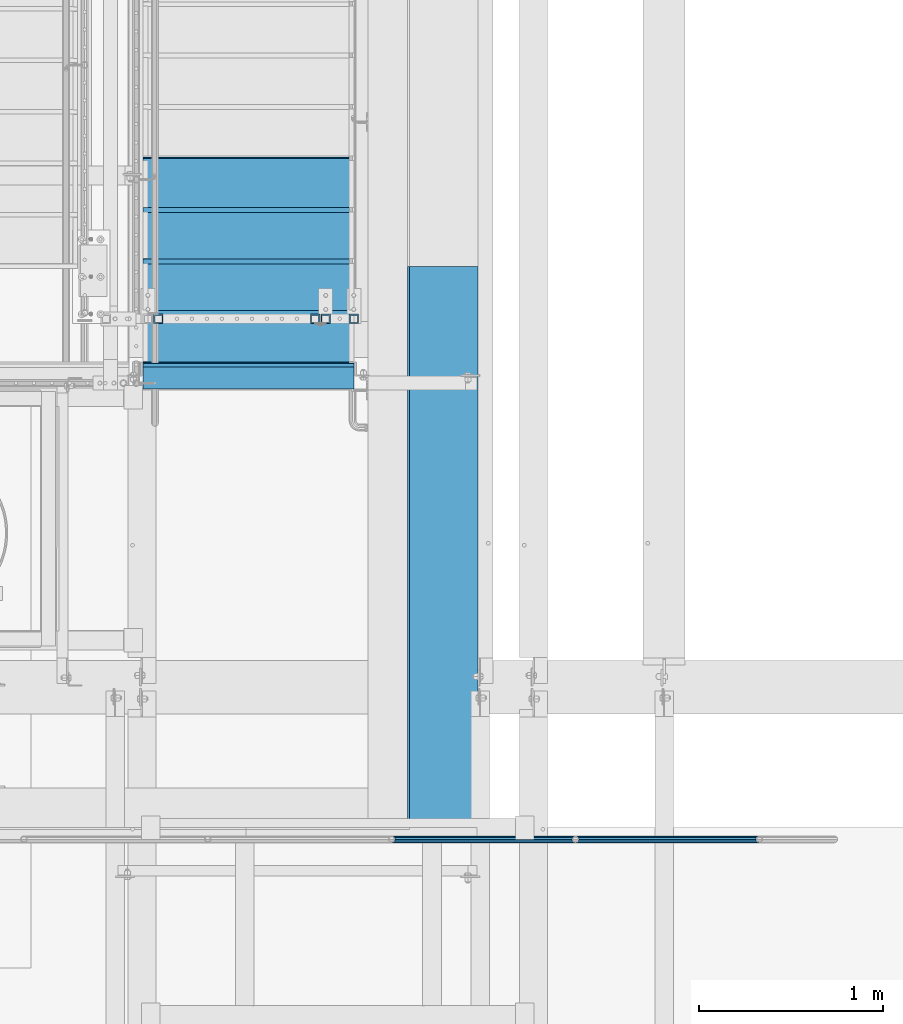
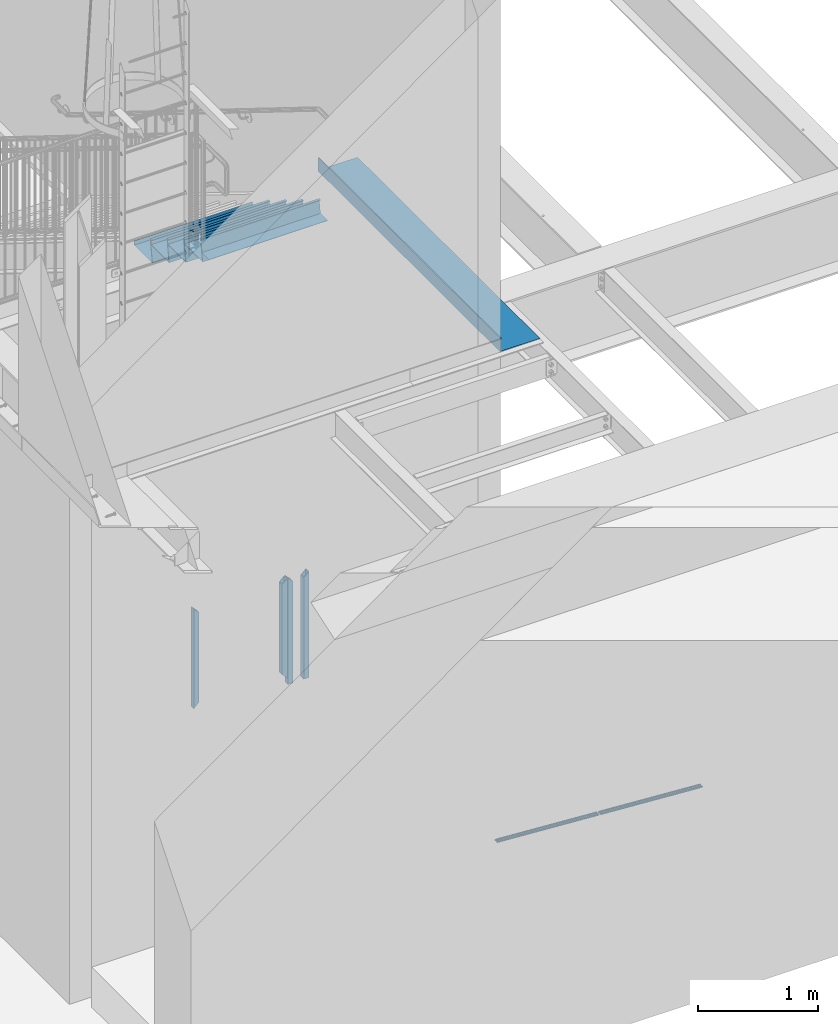
# One storey, part 1088 of 1763: 12 beams, 4 elements without a shape of their own.
"""IFC2X3 building model written with IfcOpenShell, lengths in millimetres."""

from ifc_helpers import new_model, si_unit, frame, origin_with_axes, place, context, subcontext, project, spatial, faceted_brep, material, type_object, element, aggregate, save


model = new_model("IFC2X3")

# Units and contexts
model_context = context("Model", 3, precision=1e-05, world=origin_with_axes())
body_context = subcontext(model_context, "Body", "Model", "MODEL_VIEW")
ifc_project = project(units=[si_unit("LENGTHUNIT", "METRE", prefix="MILLI"), si_unit("AREAUNIT", "SQUARE_METRE"), si_unit("VOLUMEUNIT", "CUBIC_METRE"), si_unit("MASSUNIT", "GRAM", prefix="KILO"), si_unit("TIMEUNIT", "SECOND"), si_unit("PLANEANGLEUNIT", "RADIAN"), si_unit("SOLIDANGLEUNIT", "STERADIAN"), si_unit("THERMODYNAMICTEMPERATUREUNIT", "DEGREE_CELSIUS"), si_unit("LUMINOUSINTENSITYUNIT", "LUMEN")], contexts=[model_context])

# Site, building, storey
site_placement = place(None, origin_with_axes())
site = spatial("IfcSite", under=ifc_project, at=site_placement, CompositionType="ELEMENT")
building_placement = place(site_placement, origin_with_axes())
building = spatial("IfcBuilding", under=site, at=building_placement, Name="Undefined", CompositionType="ELEMENT")
storey_placement = place(building_placement, origin_with_axes())
storey = spatial("IfcBuildingStorey", under=building, at=storey_placement, Name="Undefined", CompositionType="ELEMENT", Elevation=0.0)

# Assembly, beams
assembly_1_placement = place(storey_placement, origin_with_axes())
assembly_1 = element("IfcElementAssembly", 1, at=assembly_1_placement, inside=storey, Name="GUARDRAIL", AssemblyPlace="NOTDEFINED", PredefinedType="RIGID_FRAME")
ifc_material_1 = material()
beam_type_1 = type_object("IfcBeamType", PredefinedType="NOTDEFINED")
beam_1_placement = place(assembly_1_placement, frame((-81897.3716560389, 29197.2999999971, 147.984652267512), z_axis=(0.0, -1.0, 0.0), x_axis=(-0.997891522550524, 0.0, 0.0649038459707657)))
beam_1 = element("IfcBeam", 2, at=beam_1_placement, type_object=beam_type_1, material=ifc_material_1, Name="GUARDRAIL", context=body_context, shape_type="Brep", body=[
    faceted_brep([(1.45519152283669e-11, 1.81898940354586e-12, 19.0499999999993), (8.92561031517107, 9.52499999999873, 16.4977839420935), (10.1646410493704, -9.524999999996, 16.4977839420935), (10.1646410493704, -9.52499999999509, -16.4977839420935), (8.92561031517107, 9.52499999999873, -16.4977839420935), (1.45519152283669e-11, 1.81898940354586e-12, -19.0499999999993), (17.6056747381954, -16.4977839420881, -9.52500000000146), (17.2784488961188, -11.4667123799518, -9.52500000000146), (13.2411789904436, -7.68349999999555, -13.3082123799541), (10.6782988949999, 1.81898940354586e-12, -15.3669999999984), (12.2416941982665, 7.68350000000009, -13.3082123799541), (15.7868363965099, 11.4667123799545, -9.52500000000146), (15.4596105544624, 16.4977839420917, -9.52500000000146), (18.0907665723062, 15.3669999999984, 0.0), (17.8512206303712, 19.0499999999975, 0.0), (16.1615344449092, 13.3082123799541, -7.68349999999919), (16.1615344449092, 13.3082123799541, 7.68349999999919), (15.7868363965099, 11.4667123799545, 9.52500000000146), (15.4596105544624, 16.4977839420917, 9.52500000000146), (12.2416941982665, 7.68350000000009, 13.3082123799541), (10.6782988949999, 1.81898940354586e-12, 15.3669999999984), (13.2411789904436, -7.68349999999646, 13.3082123799541), (17.2784488961188, -11.4667123799518, 9.52500000000146), (17.6056747381954, -16.4977839420881, 9.52500000000146), (17.8926928863511, -13.3082123799504, 7.68349999999919), (20.0897361567768, -15.3669999999947, 0.0), (20.3292820987263, -19.0499999999938, 0.0), (17.8926928863511, -13.3082123799504, -7.68349999999919), (1000.15019855546, 2.72848410531878e-11, 19.0499999999993), (989.985557506108, 9.5250000000251, 16.4977839420935), (982.544523817283, 16.4977839421163, 9.52500000000146), (1000.15019855548, 2.81943357549608e-11, -19.0499999999993), (989.985557506108, 9.5250000000251, -16.4977839420935), (991.224588240293, -9.52499999997053, -16.4977839420935), (984.690588001031, -16.4977839420635, -9.52500000000146), (982.544523817283, 16.4977839421163, -9.52500000000146), (979.820916456767, 19.050000000022, 0.0), (982.257505670044, 13.3082123799786, 7.68349999999919), (980.060462398702, 15.3670000000229, 0.0), (982.87174965936, 11.46671237998, 9.52500000000146), (982.87174965936, 11.46671237998, -9.52500000000146), (982.257505670044, 13.3082123799786, -7.68349999999919), (986.909019565966, 7.68350000002556, -13.3082123799541), (989.47189966141, 2.81943357549608e-11, -15.3669999999984), (987.908504358144, -7.68349999997099, -13.3082123799541), (984.363362158969, -11.4667123799254, -9.52500000000146), (983.988664111486, -13.3082123799259, -7.68349999999919), (982.059431983173, -15.3669999999702, 0.0), (982.298977925122, -19.0499999999693, 0.0), (984.690588001031, -16.4977839420635, 9.52500000000146), (991.224588240293, -9.52499999997053, 16.4977839420935), (984.363362158969, -11.4667123799254, 9.52500000000146), (987.908504358144, -7.68349999997099, 13.3082123799541), (989.47189966141, 2.72848410531878e-11, 15.3669999999984), (986.909019565966, 7.68350000002465, 13.3082123799541), (983.988664111486, -13.3082123799259, 7.68349999999919)], [[[0, 1, 2]], [[3, 4, 5]], [[6, 7, 8, 9, 10, 11, 12, 4, 3]], [[13, 14, 12, 11, 15]], [[16, 17, 18, 14, 13]], [[2, 1, 18, 17, 19, 20, 21, 22, 23]], [[23, 22, 24, 25, 26]], [[26, 25, 27, 7, 6]], [[28, 29, 1, 0]], [[29, 30, 18, 1]], [[31, 32, 33]], [[33, 34, 6, 3]], [[31, 33, 3, 5]], [[32, 31, 5, 4]], [[35, 32, 4, 12]], [[36, 35, 12, 14]], [[30, 36, 14, 18]], [[37, 38, 36, 30, 39]], [[40, 35, 36, 38, 41]], [[33, 32, 35, 40, 42, 43, 44, 45, 34]], [[34, 45, 46, 47, 48]], [[34, 48, 26, 6]], [[49, 50, 2, 23]], [[48, 49, 23, 26]], [[50, 28, 0, 2]], [[28, 50, 29]], [[49, 51, 52, 53, 54, 39, 30, 29, 50]], [[48, 47, 55, 51, 49]], [[55, 47, 25, 24]], [[21, 52, 51, 55, 24, 22]], [[53, 52, 21, 20]], [[54, 53, 20, 19]], [[37, 39, 54, 19, 17, 16]], [[38, 37, 16, 13]], [[41, 38, 13, 15]], [[10, 42, 40, 41, 15, 11]], [[43, 42, 10, 9]], [[44, 43, 9, 8]], [[46, 45, 44, 8, 7, 27]], [[47, 46, 27, 25]]]),
])
beam_2_placement = place(assembly_1_placement, frame((-82895.4130604548, 29197.2999999971, 212.898246706029), z_axis=(0.0, -1.0, 0.0), x_axis=(-0.997891522550524, 0.0, 0.0649038459707657)))
beam_2 = element("IfcBeam", 3, at=beam_2_placement, type_object=beam_type_1, material=ifc_material_1, Name="GUARDRAIL", context=body_context, shape_type="Brep", body=[
    faceted_brep([(1.45519152283669e-11, 1.81898940354586e-12, 19.0499999999993), (8.92561031517107, 9.52499999999873, 16.4977839420935), (10.1646410493704, -9.524999999996, 16.4977839420935), (10.1646410493704, -9.52499999999509, -16.4977839420935), (8.92561031517107, 9.52499999999873, -16.4977839420935), (1.45519152283669e-11, 1.81898940354586e-12, -19.0499999999993), (17.6056747381954, -16.4977839420881, -9.52500000000146), (17.2784488961188, -11.4667123799518, -9.52500000000146), (13.2411789904436, -7.68349999999555, -13.3082123799541), (10.6782988949999, 1.81898940354586e-12, -15.3669999999984), (12.2416941982665, 7.68350000000009, -13.3082123799541), (15.7868363965099, 11.4667123799545, -9.52500000000146), (15.4596105544624, 16.4977839420917, -9.52500000000146), (18.0907665723062, 15.3669999999984, 0.0), (17.8512206303712, 19.0499999999975, 0.0), (16.1615344449092, 13.3082123799541, -7.68349999999919), (16.1615344449092, 13.3082123799541, 7.68349999999919), (15.7868363965099, 11.4667123799545, 9.52500000000146), (15.4596105544624, 16.4977839420917, 9.52500000000146), (12.2416941982665, 7.68350000000009, 13.3082123799541), (10.6782988949999, 1.81898940354586e-12, 15.3669999999984), (13.2411789904436, -7.68349999999646, 13.3082123799541), (17.2784488961188, -11.4667123799518, 9.52500000000146), (17.6056747381954, -16.4977839420881, 9.52500000000146), (17.8926928863511, -13.3082123799504, 7.68349999999919), (20.0897361567768, -15.3669999999947, 0.0), (20.3292820987263, -19.0499999999938, 0.0), (17.8926928863511, -13.3082123799504, -7.68349999999919), (1000.15019855546, 2.72848410531878e-11, 19.0499999999993), (989.985557506108, 9.5250000000251, 16.4977839420935), (982.544523817283, 16.4977839421163, 9.52500000000146), (1000.15019855548, 2.81943357549608e-11, -19.0499999999993), (989.985557506108, 9.5250000000251, -16.4977839420935), (991.224588240293, -9.52499999997053, -16.4977839420935), (984.690588001031, -16.4977839420635, -9.52500000000146), (982.544523817283, 16.4977839421163, -9.52500000000146), (979.820916456767, 19.050000000022, 0.0), (982.257505670044, 13.3082123799786, 7.68349999999919), (980.060462398702, 15.3670000000229, 0.0), (982.87174965936, 11.46671237998, 9.52500000000146), (982.87174965936, 11.46671237998, -9.52500000000146), (982.257505670044, 13.3082123799786, -7.68349999999919), (986.909019565966, 7.68350000002556, -13.3082123799541), (989.47189966141, 2.81943357549608e-11, -15.3669999999984), (987.908504358144, -7.68349999997099, -13.3082123799541), (984.363362158969, -11.4667123799254, -9.52500000000146), (983.988664111486, -13.3082123799259, -7.68349999999919), (982.059431983173, -15.3669999999702, 0.0), (982.298977925122, -19.0499999999693, 0.0), (984.690588001031, -16.4977839420635, 9.52500000000146), (991.224588240293, -9.52499999997053, 16.4977839420935), (984.363362158969, -11.4667123799254, 9.52500000000146), (987.908504358144, -7.68349999997099, 13.3082123799541), (989.47189966141, 2.72848410531878e-11, 15.3669999999984), (986.909019565966, 7.68350000002465, 13.3082123799541), (983.988664111486, -13.3082123799259, 7.68349999999919)], [[[0, 1, 2]], [[3, 4, 5]], [[6, 7, 8, 9, 10, 11, 12, 4, 3]], [[13, 14, 12, 11, 15]], [[16, 17, 18, 14, 13]], [[2, 1, 18, 17, 19, 20, 21, 22, 23]], [[23, 22, 24, 25, 26]], [[26, 25, 27, 7, 6]], [[28, 29, 1, 0]], [[29, 30, 18, 1]], [[31, 32, 33]], [[33, 34, 6, 3]], [[31, 33, 3, 5]], [[32, 31, 5, 4]], [[35, 32, 4, 12]], [[36, 35, 12, 14]], [[30, 36, 14, 18]], [[37, 38, 36, 30, 39]], [[40, 35, 36, 38, 41]], [[33, 32, 35, 40, 42, 43, 44, 45, 34]], [[34, 45, 46, 47, 48]], [[34, 48, 26, 6]], [[49, 50, 2, 23]], [[48, 49, 23, 26]], [[50, 28, 0, 2]], [[28, 50, 29]], [[49, 51, 52, 53, 54, 39, 30, 29, 50]], [[48, 47, 55, 51, 49]], [[55, 47, 25, 24]], [[21, 52, 51, 55, 24, 22]], [[53, 52, 21, 20]], [[54, 53, 20, 19]], [[37, 39, 54, 19, 17, 16]], [[38, 37, 16, 13]], [[41, 38, 13, 15]], [[10, 42, 40, 41, 15, 11]], [[43, 42, 10, 9]], [[44, 43, 9, 8]], [[46, 45, 44, 8, 7, 27]], [[47, 46, 27, 25]]]),
])
aggregate(assembly_1, [beam_1, beam_2])

assembly_2_placement = place(storey_placement, origin_with_axes())
assembly_2 = element("IfcElementAssembly", 4, at=assembly_2_placement, inside=storey, Name="GATE", AssemblyPlace="NOTDEFINED", PredefinedType="RIGID_FRAME")
beam_type_2 = type_object("IfcBeamType", Name="HSS2X2X1/4", PredefinedType="NOTDEFINED")
beam_3_placement = place(assembly_2_placement, frame((-85159.2872737343, 32023.0500064728, 1346.20003013257), z_axis=(1.0, 0.0, 0.0), x_axis=(0.0, 0.0, -1.0)))
beam_3 = element("IfcBeam", 5, at=beam_3_placement, type_object=beam_type_2, material=ifc_material_1, Name="GUARDRAIL", ObjectType="HSS2X2X1/4", context=body_context, shape_type="Brep", body=[
    faceted_brep([(-44.4500000000053, 19.0499999999993, -19.0500000000029), (-44.4500000000053, -19.0499999999993, -19.0500000000029), (958.851840643746, -19.0499999999993, -19.0500000000029), (958.851840643746, 19.0499999999993, -19.0500000000029), (-6.35000000000082, -19.0499999999993, 19.0500000000029), (920.751840643741, -19.0499999999993, 19.0500000000029), (-6.35000000000082, 19.0499999999993, 19.0500000000029), (920.751840643741, 19.0499999999993, 19.0500000000029), (-50.8000000000061, 25.4000000000015, -25.3999999999942), (1.45519152283669e-11, 25.4000000000015, 25.3999999999796), (914.401840643741, 25.4000000000015, 25.3999999999942), (965.201840643746, 25.4000000000015, -25.3999999999942), (0.0, -25.4000000000015, 25.3999999999942), (914.401840643741, -25.4000000000015, 25.3999999999942), (-50.8000000000061, -25.4000000000015, -25.3999999999942), (965.201840643746, -25.4000000000015, -25.3999999999942)], [[[0, 1, 2, 3]], [[1, 4, 5, 2]], [[4, 6, 7, 5]], [[6, 0, 3, 7]], [[8, 9, 10, 11]], [[9, 12, 13, 10]], [[12, 14, 15, 13]], [[14, 8, 11, 15]], [[13, 15, 11, 10], [5, 7, 3, 2]], [[14, 12, 9, 8], [6, 4, 1, 0]]]),
])
beam_4_placement = place(assembly_2_placement, frame((-84308.3872737343, 32023.0500064728, 1346.20003013257), z_axis=(1.0, 0.0, 0.0), x_axis=(0.0, 0.0, -1.0)))
beam_4 = element("IfcBeam", 6, at=beam_4_placement, type_object=beam_type_2, material=ifc_material_1, Name="GUARDRAIL", ObjectType="HSS2X2X1/4", context=body_context, shape_type="Brep", body=[
    faceted_brep([(-6.34999999999491, 19.0499999999993, -19.0500000000029), (-6.34999999999491, -19.0499999999993, -19.0500000000029), (920.751840643747, -19.0499999999993, -19.0500000000029), (920.751840643747, 19.0499999999993, -19.0500000000029), (-44.4499999999994, -19.0499999999993, 19.0500000000029), (958.851840643751, -19.0499999999993, 19.0500000000029), (-44.4499999999994, 19.0499999999993, 19.0500000000029), (958.851840643751, 19.0499999999993, 19.0500000000029), (-1.45519152283669e-11, 25.4000000000015, -25.3999999999869), (-50.8000000000002, 25.4000000000015, 25.3999999999942), (965.201840643752, 25.4000000000015, 25.3999999999942), (914.401840643746, 25.4000000000015, -25.3999999999942), (-50.8000000000002, -25.4000000000015, 25.3999999999942), (965.201840643752, -25.4000000000015, 25.3999999999942), (-1.45519152283669e-11, -25.4000000000015, -25.3999999999869), (914.401840643746, -25.4000000000015, -25.3999999999942)], [[[0, 1, 2, 3]], [[1, 4, 5, 2]], [[4, 6, 7, 5]], [[6, 0, 3, 7]], [[8, 9, 10, 11]], [[9, 12, 13, 10]], [[12, 14, 15, 13]], [[14, 8, 11, 15]], [[13, 15, 11, 10], [5, 7, 3, 2]], [[14, 12, 9, 8], [6, 4, 1, 0]]]),
])
beam_5_placement = place(assembly_2_placement, frame((-84098.8372737343, 32023.0500064728, 1397.00003013257), z_axis=(1.0, 0.0, 0.0), x_axis=(0.0, 0.0, -1.0)))
beam_5 = element("IfcBeam", 7, at=beam_5_placement, type_object=beam_type_2, material=ifc_material_1, Name="GUARDRAIL", ObjectType="HSS2X2X1/4", context=body_context, shape_type="Brep", body=[
    faceted_brep([(44.4500000000053, 19.0499999999993, -19.0500000000029), (44.4500000000053, -19.0499999999993, -19.0500000000029), (1085.85, -19.0499999999993, -19.0500000000029), (1085.85, 19.0499999999993, -19.0500000000029), (6.35000000000082, -19.0499999999993, 19.0500000000029), (1085.85, -19.0499999999993, 19.0500000000029), (6.35000000000082, 19.0499999999993, 19.0500000000029), (1085.85, 19.0499999999993, 19.0500000000029), (50.7999999999884, 25.3999999999996, -25.3999999999996), (1.45519152283669e-11, 25.4000000000015, 25.3999999999796), (1085.85, 25.4000000000015, 25.3999999999942), (1085.85, 25.4000000000015, -25.3999999999942), (0.0, -25.4000000000015, 25.3999999999942), (1085.85, -25.4000000000015, 25.3999999999942), (50.7999999999884, -25.3999999999996, -25.3999999999996), (1085.85, -25.4000000000015, -25.3999999999942)], [[[0, 1, 2, 3]], [[1, 4, 5, 2]], [[4, 6, 7, 5]], [[6, 0, 3, 7]], [[8, 9, 10, 11]], [[9, 12, 13, 10]], [[12, 14, 15, 13]], [[14, 8, 11, 15]], [[13, 15, 11, 10], [5, 7, 3, 2]], [[14, 12, 9, 8], [6, 4, 1, 0]]]),
])
beam_6_placement = place(assembly_2_placement, frame((-84251.2372737343, 32023.0500064728, 1371.60003013257), z_axis=(1.0, 0.0, 0.0), x_axis=(0.0, 0.0, -1.0)))
beam_6 = element("IfcBeam", 8, at=beam_6_placement, type_object=beam_type_2, material=ifc_material_1, Name="GUARDRAIL", ObjectType="HSS2X2X1/4", context=body_context, shape_type="Brep", body=[
    faceted_brep([(-19.0500000000052, 19.0499999999993, -19.0500000000029), (-19.0500000000052, -19.0499999999993, -19.0500000000029), (1060.45, -19.0499999999993, -19.0500000000029), (1060.45, 19.0499999999993, -19.0500000000029), (19.0499999999993, -19.0499999999993, 19.0500000000029), (1060.45, -19.0499999999993, 19.0500000000029), (19.0499999999993, 19.0499999999993, 19.0500000000029), (1060.45, 19.0499999999993, 19.0500000000029), (-25.400000000006, 25.4000000000015, -25.3999999999942), (25.4000000000001, 25.4000000000015, 25.3999999999942), (1060.45, 25.4000000000015, 25.3999999999942), (1060.45, 25.4000000000015, -25.3999999999942), (25.4000000000001, -25.4000000000015, 25.3999999999942), (1060.45, -25.4000000000015, 25.3999999999942), (-25.400000000006, -25.4000000000015, -25.3999999999942), (1060.45, -25.4000000000015, -25.3999999999942)], [[[0, 1, 2, 3]], [[1, 4, 5, 2]], [[4, 6, 7, 5]], [[6, 0, 3, 7]], [[8, 9, 10, 11]], [[9, 12, 13, 10]], [[12, 14, 15, 13]], [[14, 8, 11, 15]], [[13, 15, 11, 10], [5, 7, 3, 2]], [[14, 12, 9, 8], [6, 4, 1, 0]]]),
])
aggregate(assembly_2, [beam_3, beam_4, beam_5, beam_6])

# Assembly, beam
assembly_3_placement = place(storey_placement, origin_with_axes())
assembly_3 = element("IfcElementAssembly", 9, at=assembly_3_placement, inside=storey, Name="BEAM", AssemblyPlace="NOTDEFINED", PredefinedType="RIGID_FRAME")
ifc_material_2 = material(Name="STEEL/A36")
beam_type_3 = type_object("IfcBeamType", PredefinedType="NOTDEFINED")
beam_7_placement = place(assembly_3_placement, frame((-83425.7372736983, 30784.00575, 5199.0625), z_axis=(0.0, -1.0, 0.0), x_axis=(-1.0, 0.0, 0.0)))
beam_7 = element("IfcBeam", 10, at=beam_7_placement, type_object=beam_type_3, material=ifc_material_2, Name="BENT_PLATE", context=body_context, shape_type="Brep", body=[
    faceted_brep([(0.0, -4.76249999999982, -1524.0), (0.0, -4.76249999999982, 1524.0), (0.0, 4.76249999999982, 1524.0), (0.0, 4.76249999999982, -1524.0), (381.0, 4.76249999999982, 1524.0), (381.0, 4.76249999999982, -1524.0), (371.475000000006, -4.76249999999982, -1524.0), (371.475000000006, -4.76249999999982, 1524.0), (381.0, -134.937496948242, 1524.0), (381.0, -134.937496948242, -1524.0), (371.475000000006, -134.937496948242, 1524.0), (371.475000000006, -134.937496948242, -1524.0)], [[[0, 1, 2, 3]], [[3, 2, 4, 5]], [[1, 0, 6, 7]], [[5, 4, 8, 9]], [[4, 2, 1, 7, 10, 8]], [[7, 6, 11, 10]], [[6, 0, 3, 5, 9, 11]], [[10, 11, 9, 8]]]),
])
aggregate(assembly_3, [beam_7])

# Assembly, beams
assembly_4_placement = place(storey_placement, origin_with_axes())
assembly_4 = element("IfcElementAssembly", 11, at=assembly_4_placement, inside=storey, Name="STRINGER", AssemblyPlace="NOTDEFINED", PredefinedType="RIGID_FRAME")
beam_type_4 = type_object("IfcBeamType", PredefinedType="NOTDEFINED")
beam_8_placement = place(assembly_4_placement, frame((-84670.272101246, 31642.0500001343, 5195.88750001325), z_axis=(-1.0, 0.0, 0.0), x_axis=(0.0, 1.0, 0.0)))
beam_8 = element("IfcBeam", 12, at=beam_8_placement, type_object=beam_type_4, material=ifc_material_2, Name="TREAD", context=body_context, shape_type="Brep", body=[
    faceted_brep([(0.0, -1.58749999999964, -571.5), (0.0, -1.58749999999964, 571.5), (0.0, 1.58749999999964, 571.5), (0.0, 1.58749999999964, -571.5), (122.384764270853, 1.58750000012969, 571.5), (122.384764270853, 1.58750000012969, -571.5), (119.640823364254, -1.58749999987322, -571.5), (119.640823364254, -1.58749999987322, 571.5), (140.855243789152, -124.550469203636, 571.5), (140.855243789152, -124.550469203636, -571.5), (137.713745117184, -125.010481262207, 571.5), (137.713745117184, -125.010481262207, -571.5)], [[[0, 1, 2, 3]], [[3, 2, 4, 5]], [[1, 0, 6, 7]], [[5, 4, 8, 9]], [[4, 2, 1, 7, 10, 8]], [[7, 6, 11, 10]], [[6, 0, 3, 5, 9, 11]], [[10, 11, 9, 8]]]),
])
beam_type_5 = type_object("IfcBeamType", PredefinedType="NOTDEFINED")
beam_9_placement = place(assembly_4_placement, frame((-84670.272101313, 31762.6999999968, 5332.41250001325), z_axis=(-1.0, 0.0, 0.0), x_axis=(0.0, 1.0, 0.0)))
beam_9 = element("IfcBeam", 13, at=beam_9_placement, type_object=beam_type_5, material=ifc_material_2, Name="TREAD", context=body_context, shape_type="Brep", body=[
    faceted_brep([(0.0, -1.58749999999964, -571.5), (0.0, -1.58749999999964, 571.5), (0.0, 1.58749999999964, 571.5), (0.0, 1.58749999999964, -571.5), (21.7262234107766, 1.58750000001965, 571.5), (21.7262234107766, 1.58750000001965, -571.5), (25.3999996185303, -1.58749999999998, -571.5), (25.3999996185303, -1.58749999999998, 571.5), (-11.1124582870689, 225.848333740234, 571.5), (-11.1124582870689, 225.848333740234, -571.5), (-7.43868207930791, 222.673333740234, -571.5), (-7.43868207930791, 222.673333740234, 571.5), (293.687544632128, 225.848333740234, 571.5), (293.687544632128, 225.848333740234, -571.5), (290.943603515625, 222.673333740234, -571.5), (290.943603515625, 222.673333740234, 571.5), (299.605243823971, 185.435362772942, 571.5), (299.605243823971, 185.435362772942, -571.5), (296.463745117188, 184.975350952148, 571.5), (296.463745117188, 184.975350952148, -571.5)], [[[0, 1, 2, 3]], [[3, 2, 4, 5]], [[1, 0, 6, 7]], [[5, 4, 8, 9]], [[7, 6, 10, 11]], [[9, 8, 12, 13]], [[11, 10, 14, 15]], [[13, 12, 16, 17]], [[12, 8, 4, 2, 1, 7, 11, 15, 18, 16]], [[15, 14, 19, 18]], [[14, 10, 6, 0, 3, 5, 9, 13, 17, 19]], [[18, 19, 17, 16]]]),
])
beam_10_placement = place(assembly_4_placement, frame((-84670.272101313, 32042.1000000807, 5158.95166667991), z_axis=(-1.0, 0.0, 0.0), x_axis=(0.0, 1.0, 0.0)))
beam_10 = element("IfcBeam", 14, at=beam_10_placement, type_object=beam_type_5, material=ifc_material_2, Name="TREAD", context=body_context, shape_type="Brep", body=[
    faceted_brep([(0.0, -1.58749999999964, -571.5), (0.0, -1.58749999999964, 571.5), (0.0, 1.58749999999964, 571.5), (0.0, 1.58749999999964, -571.5), (21.7262234107766, 1.58750000001965, 571.5), (21.7262234107766, 1.58750000001965, -571.5), (25.3999996185303, -1.58749999999998, -571.5), (25.3999996185303, -1.58749999999998, 571.5), (-11.1124582870689, 225.848333740234, 571.5), (-11.1124582870689, 225.848333740234, -571.5), (-7.43868207930791, 222.673333740234, -571.5), (-7.43868207930791, 222.673333740234, 571.5), (293.687544632128, 225.848333740234, 571.5), (293.687544632128, 225.848333740234, -571.5), (290.943603515625, 222.673333740234, -571.5), (290.943603515625, 222.673333740234, 571.5), (299.605243823971, 185.435362772942, 571.5), (299.605243823971, 185.435362772942, -571.5), (296.463745117188, 184.975350952148, 571.5), (296.463745117188, 184.975350952148, -571.5)], [[[0, 1, 2, 3]], [[3, 2, 4, 5]], [[1, 0, 6, 7]], [[5, 4, 8, 9]], [[7, 6, 10, 11]], [[9, 8, 12, 13]], [[11, 10, 14, 15]], [[13, 12, 16, 17]], [[12, 8, 4, 2, 1, 7, 11, 15, 18, 16]], [[15, 14, 19, 18]], [[14, 10, 6, 0, 3, 5, 9, 13, 17, 19]], [[18, 19, 17, 16]]]),
])
beam_11_placement = place(assembly_4_placement, frame((-84670.272101313, 32321.5000001646, 4985.49083334658), z_axis=(-1.0, 0.0, 0.0), x_axis=(0.0, 1.0, 0.0)))
beam_11 = element("IfcBeam", 15, at=beam_11_placement, type_object=beam_type_5, material=ifc_material_2, Name="TREAD", context=body_context, shape_type="Brep", body=[
    faceted_brep([(0.0, -1.58749999999964, -571.5), (0.0, -1.58749999999964, 571.5), (0.0, 1.58749999999964, 571.5), (0.0, 1.58749999999964, -571.5), (21.7262234107766, 1.58750000001965, 571.5), (21.7262234107766, 1.58750000001965, -571.5), (25.3999996185303, -1.58749999999998, -571.5), (25.3999996185303, -1.58749999999998, 571.5), (-11.1124582870689, 225.848333740234, 571.5), (-11.1124582870689, 225.848333740234, -571.5), (-7.43868207930791, 222.673333740234, -571.5), (-7.43868207930791, 222.673333740234, 571.5), (293.687544632128, 225.848333740234, 571.5), (293.687544632128, 225.848333740234, -571.5), (290.943603515625, 222.673333740234, -571.5), (290.943603515625, 222.673333740234, 571.5), (299.605243823971, 185.435362772942, 571.5), (299.605243823971, 185.435362772942, -571.5), (296.463745117188, 184.975350952148, 571.5), (296.463745117188, 184.975350952148, -571.5)], [[[0, 1, 2, 3]], [[3, 2, 4, 5]], [[1, 0, 6, 7]], [[5, 4, 8, 9]], [[7, 6, 10, 11]], [[9, 8, 12, 13]], [[11, 10, 14, 15]], [[13, 12, 16, 17]], [[12, 8, 4, 2, 1, 7, 11, 15, 18, 16]], [[15, 14, 19, 18]], [[14, 10, 6, 0, 3, 5, 9, 13, 17, 19]], [[18, 19, 17, 16]]]),
])
beam_12_placement = place(assembly_4_placement, frame((-84670.272101313, 32600.9000002485, 4812.03000001325), z_axis=(-1.0, 0.0, 0.0), x_axis=(0.0, 1.0, 0.0)))
beam_12 = element("IfcBeam", 16, at=beam_12_placement, type_object=beam_type_5, material=ifc_material_2, Name="TREAD", context=body_context, shape_type="Brep", body=[
    faceted_brep([(0.0, -1.58749999999964, -571.5), (0.0, -1.58749999999964, 571.5), (0.0, 1.58749999999964, 571.5), (0.0, 1.58749999999964, -571.5), (21.7262234107766, 1.58750000001965, 571.5), (21.7262234107766, 1.58750000001965, -571.5), (25.3999996185303, -1.58749999999998, -571.5), (25.3999996185303, -1.58749999999998, 571.5), (-11.1124582870689, 225.848333740234, 571.5), (-11.1124582870689, 225.848333740234, -571.5), (-7.43868207930791, 222.673333740234, -571.5), (-7.43868207930791, 222.673333740234, 571.5), (293.687544632128, 225.848333740234, 571.5), (293.687544632128, 225.848333740234, -571.5), (290.943603515625, 222.673333740234, -571.5), (290.943603515625, 222.673333740234, 571.5), (299.605243823971, 185.435362772942, 571.5), (299.605243823971, 185.435362772942, -571.5), (296.463745117188, 184.975350952148, 571.5), (296.463745117188, 184.975350952148, -571.5)], [[[0, 1, 2, 3]], [[3, 2, 4, 5]], [[1, 0, 6, 7]], [[5, 4, 8, 9]], [[7, 6, 10, 11]], [[9, 8, 12, 13]], [[11, 10, 14, 15]], [[13, 12, 16, 17]], [[12, 8, 4, 2, 1, 7, 11, 15, 18, 16]], [[15, 14, 19, 18]], [[14, 10, 6, 0, 3, 5, 9, 13, 17, 19]], [[18, 19, 17, 16]]]),
])
aggregate(assembly_4, [beam_8, beam_9, beam_10, beam_11, beam_12])

save(model, "model.ifc")
